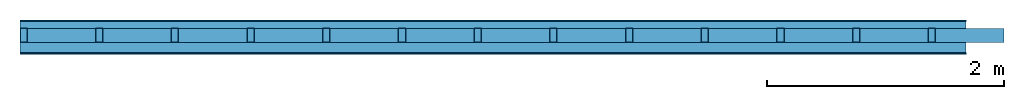
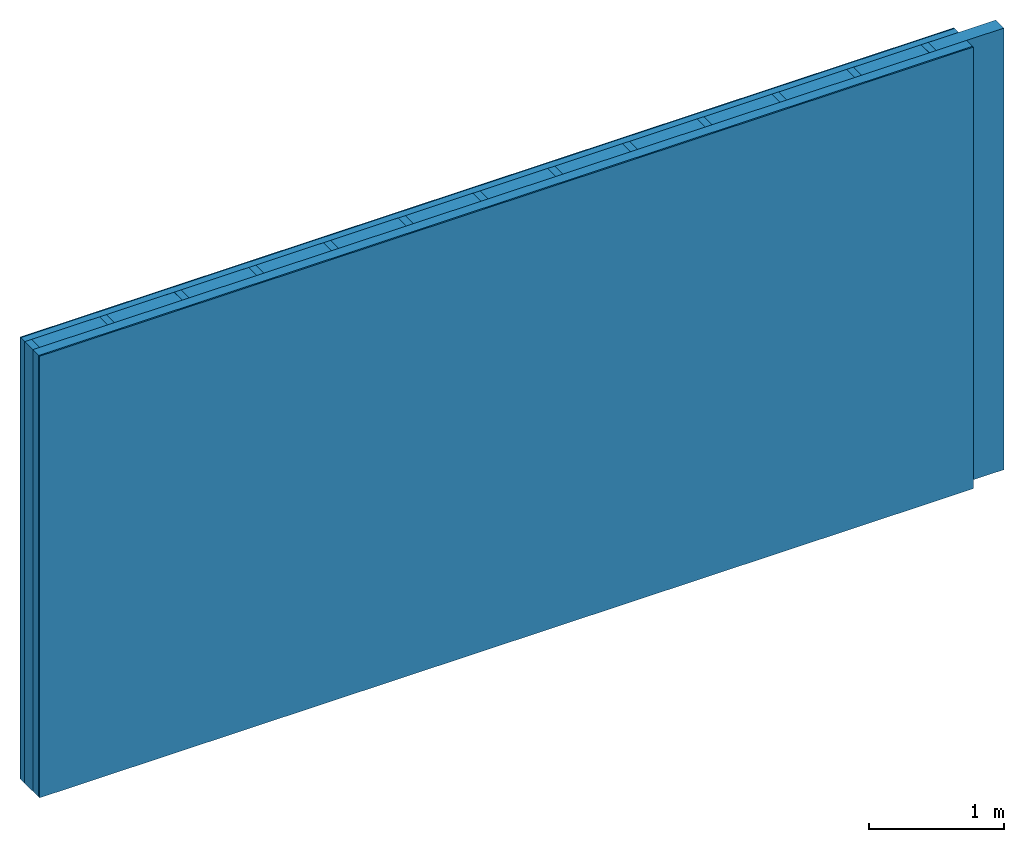
# One storey: 4 plates, 2 members, 1 element without a shape of its own.
"""IFC4 building model written with IfcOpenShell, lengths in metres."""

from ifc_helpers import new_model, si_unit, derived_unit, direction, frame, frame_2d, origin, origin_with_axes, place, context, project, spatial, rectangle, extrude, material, layer, layer_set, type_object, element, aggregate, save


model = new_model("IFC4")

# Units and contexts
plan_context = context("Plan", 3, precision=1e-05, world=origin(), true_north=direction((0.0, 1.0)))
model_context = context("Model", 3, precision=1e-05, world=origin(), true_north=direction((0.0, 1.0)))
ifc_project = project(units=[si_unit("LENGTHUNIT", "METRE"), derived_unit("SOUNDPRESSUREUNIT", [(si_unit("PRESSUREUNIT", "PASCAL", prefix="MICRO"), 0)]), si_unit("ENERGYUNIT", "JOULE", prefix="MEGA"), si_unit("MASSUNIT", "GRAM", prefix="KILO"), derived_unit("THERMALTRANSMITTANCEUNIT", [(si_unit("POWERUNIT", "WATT"), 1), (si_unit("AREAUNIT", "SQUARE_METRE"), -1), (si_unit("THERMODYNAMICTEMPERATUREUNIT", "KELVIN"), -1)]), derived_unit("AREADENSITYUNIT", [(si_unit("MASSUNIT", "GRAM", prefix="KILO"), 1), (si_unit("AREAUNIT", "SQUARE_METRE"), -1)]), derived_unit("USERDEFINED", [(si_unit("ENERGYUNIT", "JOULE", prefix="MEGA"), 1), (si_unit("AREAUNIT", "SQUARE_METRE"), -1)])], contexts=[plan_context, model_context])

# Site, building, storey
site = spatial("IfcSite", under=ifc_project)
building_placement = place(None, origin())
building = spatial("IfcBuilding", under=site, at=building_placement)
storey_placement = place(building_placement, origin())
storey = spatial("IfcBuildingStorey", under=building, at=storey_placement)

# Wall, members, plates
ifc_material_1 = material(Category="04.011")
ifc_layer_1 = layer(ifc_material_1, 0.01, Name="Surface 1")
ifc_material_2 = material(Category="10.009")
ifc_layer_2 = layer(ifc_material_2, 0.06, Name="outside 1st layer")
ifc_material_3 = material(Name="of the art")
ifc_layer_3 = layer(ifc_material_3, 0.0, Name="Bond")
ifc_layer_4 = layer(None, 0.12, Name="Support")
ifc_layer_5 = layer(ifc_material_3, 0.0, Name="Bond")
ifc_material_4 = material(Name="Solid timber panel")
ifc_layer_6 = layer(ifc_material_4, 0.087, Name="1st layer")
ifc_material_5 = material(Name="Plasterboard type A", Category="03.008")
ifc_layer_7 = layer(ifc_material_5, 0.0125, Name="Covering 1st layer")
ifc_material_6 = material(Name="joints", Category="04.017")
ifc_layer_8 = layer(ifc_material_6, 0.0, Name="Surface")
ifc_layer_set = layer_set([ifc_layer_1, ifc_layer_2, ifc_layer_3, ifc_layer_4, ifc_layer_5, ifc_layer_6, ifc_layer_7, ifc_layer_8])
wall_type = type_object("IfcWallType", Name="D0979", PredefinedType="NOTDEFINED", material=ifc_layer_set)
wall_placement = place(None, frame((0.0, 0.0, 0.0), z_axis=(0.0, -1.0, 0.0), x_axis=(1.0, 0.0, 0.0)))
wall = element("IfcWall", 1, at=wall_placement, inside=storey, type_object=wall_type, material=ifc_layer_set, Name="Wall #1")
ifc_material_7 = material()
member_1_placement = place(wall_placement, origin())
member_1 = element("IfcMember", 2, at=member_1_placement, material=ifc_material_7, Name="Support", context=plan_context, shape_type="SweptSolid", body=[
    extrude(rectangle(XDim=0.06, YDim=0.12, at=frame_2d((0.03, 0.06), x_axis=(1.0, 0.0))), frame((0.0, 4.0, 0.07), z_axis=(0.0, -1.0, 0.0), x_axis=(1.0, 0.0, 0.0)), (0.0, 0.0, 1.0), 4.0),
    extrude(rectangle(XDim=0.06, YDim=0.12, at=frame_2d((0.03, 0.06), x_axis=(1.0, 0.0))), frame((0.64, 4.0, 0.07), z_axis=(0.0, -1.0, 0.0), x_axis=(1.0, 0.0, 0.0)), (0.0, 0.0, 1.0), 4.0),
    extrude(rectangle(XDim=0.06, YDim=0.12, at=frame_2d((0.03, 0.06), x_axis=(1.0, 0.0))), frame((1.28, 4.0, 0.07), z_axis=(0.0, -1.0, 0.0), x_axis=(1.0, 0.0, 0.0)), (0.0, 0.0, 1.0), 4.0),
    extrude(rectangle(XDim=0.06, YDim=0.12, at=frame_2d((0.03, 0.06), x_axis=(1.0, 0.0))), frame((1.92, 4.0, 0.07), z_axis=(0.0, -1.0, 0.0), x_axis=(1.0, 0.0, 0.0)), (0.0, 0.0, 1.0), 4.0),
    extrude(rectangle(XDim=0.06, YDim=0.12, at=frame_2d((0.03, 0.06), x_axis=(1.0, 0.0))), frame((2.56, 4.0, 0.07), z_axis=(0.0, -1.0, 0.0), x_axis=(1.0, 0.0, 0.0)), (0.0, 0.0, 1.0), 4.0),
    extrude(rectangle(XDim=0.06, YDim=0.12, at=frame_2d((0.03, 0.06), x_axis=(1.0, 0.0))), frame((3.2, 4.0, 0.07), z_axis=(0.0, -1.0, 0.0), x_axis=(1.0, 0.0, 0.0)), (0.0, 0.0, 1.0), 4.0),
    extrude(rectangle(XDim=0.06, YDim=0.12, at=frame_2d((0.03, 0.06), x_axis=(1.0, 0.0))), frame((3.84, 4.0, 0.07), z_axis=(0.0, -1.0, 0.0), x_axis=(1.0, 0.0, 0.0)), (0.0, 0.0, 1.0), 4.0),
    extrude(rectangle(XDim=0.06, YDim=0.12, at=frame_2d((0.03, 0.06), x_axis=(1.0, 0.0))), frame((4.48, 4.0, 0.07), z_axis=(0.0, -1.0, 0.0), x_axis=(1.0, 0.0, 0.0)), (0.0, 0.0, 1.0), 4.0),
    extrude(rectangle(XDim=0.06, YDim=0.12, at=frame_2d((0.03, 0.06), x_axis=(1.0, 0.0))), frame((5.12, 4.0, 0.07), z_axis=(0.0, -1.0, 0.0), x_axis=(1.0, 0.0, 0.0)), (0.0, 0.0, 1.0), 4.0),
    extrude(rectangle(XDim=0.06, YDim=0.12, at=frame_2d((0.03, 0.06), x_axis=(1.0, 0.0))), frame((5.76, 4.0, 0.07), z_axis=(0.0, -1.0, 0.0), x_axis=(1.0, 0.0, 0.0)), (0.0, 0.0, 1.0), 4.0),
    extrude(rectangle(XDim=0.06, YDim=0.12, at=frame_2d((0.03, 0.06), x_axis=(1.0, 0.0))), frame((6.4, 4.0, 0.07), z_axis=(0.0, -1.0, 0.0), x_axis=(1.0, 0.0, 0.0)), (0.0, 0.0, 1.0), 4.0),
    extrude(rectangle(XDim=0.06, YDim=0.12, at=frame_2d((0.03, 0.06), x_axis=(1.0, 0.0))), frame((7.04, 4.0, 0.07), z_axis=(0.0, -1.0, 0.0), x_axis=(1.0, 0.0, 0.0)), (0.0, 0.0, 1.0), 4.0),
    extrude(rectangle(XDim=0.06, YDim=0.12, at=frame_2d((0.03, 0.06), x_axis=(1.0, 0.0))), frame((7.68, 4.0, 0.07), z_axis=(0.0, -1.0, 0.0), x_axis=(1.0, 0.0, 0.0)), (0.0, 0.0, 1.0), 4.0),
])
ifc_material_8 = material()
member_2_placement = place(wall_placement, origin())
member_2 = element("IfcMember", 3, at=member_2_placement, material=ifc_material_8, Name="Cavity", context=plan_context, shape_type="SweptSolid", body=[
    extrude(rectangle(XDim=0.58, YDim=0.12, at=frame_2d((0.29, 0.06), x_axis=(1.0, 0.0))), frame((0.06, 4.0, 0.07), z_axis=(0.0, -1.0, 0.0), x_axis=(1.0, 0.0, 0.0)), (0.0, 0.0, 1.0), 4.0),
    extrude(rectangle(XDim=0.58, YDim=0.12, at=frame_2d((0.29, 0.06), x_axis=(1.0, 0.0))), frame((0.7, 4.0, 0.07), z_axis=(0.0, -1.0, 0.0), x_axis=(1.0, 0.0, 0.0)), (0.0, 0.0, 1.0), 4.0),
    extrude(rectangle(XDim=0.58, YDim=0.12, at=frame_2d((0.29, 0.06), x_axis=(1.0, 0.0))), frame((1.34, 4.0, 0.07), z_axis=(0.0, -1.0, 0.0), x_axis=(1.0, 0.0, 0.0)), (0.0, 0.0, 1.0), 4.0),
    extrude(rectangle(XDim=0.58, YDim=0.12, at=frame_2d((0.29, 0.06), x_axis=(1.0, 0.0))), frame((1.98, 4.0, 0.07), z_axis=(0.0, -1.0, 0.0), x_axis=(1.0, 0.0, 0.0)), (0.0, 0.0, 1.0), 4.0),
    extrude(rectangle(XDim=0.58, YDim=0.12, at=frame_2d((0.29, 0.06), x_axis=(1.0, 0.0))), frame((2.62, 4.0, 0.07), z_axis=(0.0, -1.0, 0.0), x_axis=(1.0, 0.0, 0.0)), (0.0, 0.0, 1.0), 4.0),
    extrude(rectangle(XDim=0.58, YDim=0.12, at=frame_2d((0.29, 0.06), x_axis=(1.0, 0.0))), frame((3.26, 4.0, 0.07), z_axis=(0.0, -1.0, 0.0), x_axis=(1.0, 0.0, 0.0)), (0.0, 0.0, 1.0), 4.0),
    extrude(rectangle(XDim=0.58, YDim=0.12, at=frame_2d((0.29, 0.06), x_axis=(1.0, 0.0))), frame((3.9, 4.0, 0.07), z_axis=(0.0, -1.0, 0.0), x_axis=(1.0, 0.0, 0.0)), (0.0, 0.0, 1.0), 4.0),
    extrude(rectangle(XDim=0.58, YDim=0.12, at=frame_2d((0.29, 0.06), x_axis=(1.0, 0.0))), frame((4.54, 4.0, 0.07), z_axis=(0.0, -1.0, 0.0), x_axis=(1.0, 0.0, 0.0)), (0.0, 0.0, 1.0), 4.0),
    extrude(rectangle(XDim=0.58, YDim=0.12, at=frame_2d((0.29, 0.06), x_axis=(1.0, 0.0))), frame((5.18, 4.0, 0.07), z_axis=(0.0, -1.0, 0.0), x_axis=(1.0, 0.0, 0.0)), (0.0, 0.0, 1.0), 4.0),
    extrude(rectangle(XDim=0.58, YDim=0.12, at=frame_2d((0.29, 0.06), x_axis=(1.0, 0.0))), frame((5.82, 4.0, 0.07), z_axis=(0.0, -1.0, 0.0), x_axis=(1.0, 0.0, 0.0)), (0.0, 0.0, 1.0), 4.0),
    extrude(rectangle(XDim=0.58, YDim=0.12, at=frame_2d((0.29, 0.06), x_axis=(1.0, 0.0))), frame((6.46, 4.0, 0.07), z_axis=(0.0, -1.0, 0.0), x_axis=(1.0, 0.0, 0.0)), (0.0, 0.0, 1.0), 4.0),
    extrude(rectangle(XDim=0.58, YDim=0.12, at=frame_2d((0.29, 0.06), x_axis=(1.0, 0.0))), frame((7.1, 4.0, 0.07), z_axis=(0.0, -1.0, 0.0), x_axis=(1.0, 0.0, 0.0)), (0.0, 0.0, 1.0), 4.0),
    extrude(rectangle(XDim=0.58, YDim=0.12, at=frame_2d((0.29, 0.06), x_axis=(1.0, 0.0))), frame((7.74, 4.0, 0.07), z_axis=(0.0, -1.0, 0.0), x_axis=(1.0, 0.0, 0.0)), (0.0, 0.0, 1.0), 4.0),
])
plate_1_placement = place(wall_placement, origin())
plate_1 = element("IfcPlate", 4, at=plate_1_placement, material=ifc_material_1, Name="Surface 1", context=plan_context, shape_type="SweptSolid", body=[
    extrude(rectangle(XDim=8.0, YDim=4.0, at=frame_2d((4.0, 2.0), x_axis=(1.0, 0.0))), origin_with_axes(), (0.0, 0.0, 1.0), 0.01),
])
plate_2_placement = place(wall_placement, origin())
plate_2 = element("IfcPlate", 5, at=plate_2_placement, material=ifc_material_2, Name="outside 1st layer", context=plan_context, shape_type="SweptSolid", body=[
    extrude(rectangle(XDim=8.0, YDim=4.0, at=frame_2d((4.0, 2.0), x_axis=(1.0, 0.0))), frame((0.0, 0.0, 0.01), z_axis=(0.0, 0.0, 1.0), x_axis=(1.0, 0.0, 0.0)), (0.0, 0.0, 1.0), 0.06),
])
plate_3_placement = place(wall_placement, origin())
plate_3 = element("IfcPlate", 6, at=plate_3_placement, material=ifc_material_4, Name="1st layer", context=plan_context, shape_type="SweptSolid", body=[
    extrude(rectangle(XDim=8.0, YDim=4.0, at=frame_2d((4.0, 2.0), x_axis=(1.0, 0.0))), frame((0.0, 0.0, 0.19), z_axis=(0.0, 0.0, 1.0), x_axis=(1.0, 0.0, 0.0)), (0.0, 0.0, 1.0), 0.087),
])
plate_4_placement = place(wall_placement, origin())
plate_4 = element("IfcPlate", 7, at=plate_4_placement, material=ifc_material_5, Name="Covering 1st layer", context=plan_context, shape_type="SweptSolid", body=[
    extrude(rectangle(XDim=8.0, YDim=4.0, at=frame_2d((4.0, 2.0), x_axis=(1.0, 0.0))), frame((0.0, 0.0, 0.277), z_axis=(0.0, 0.0, 1.0), x_axis=(1.0, 0.0, 0.0)), (0.0, 0.0, 1.0), 0.0125),
])
aggregate(wall, [plate_1, plate_2, member_1, member_2, plate_3, plate_4])

save(model, "model.ifc")
